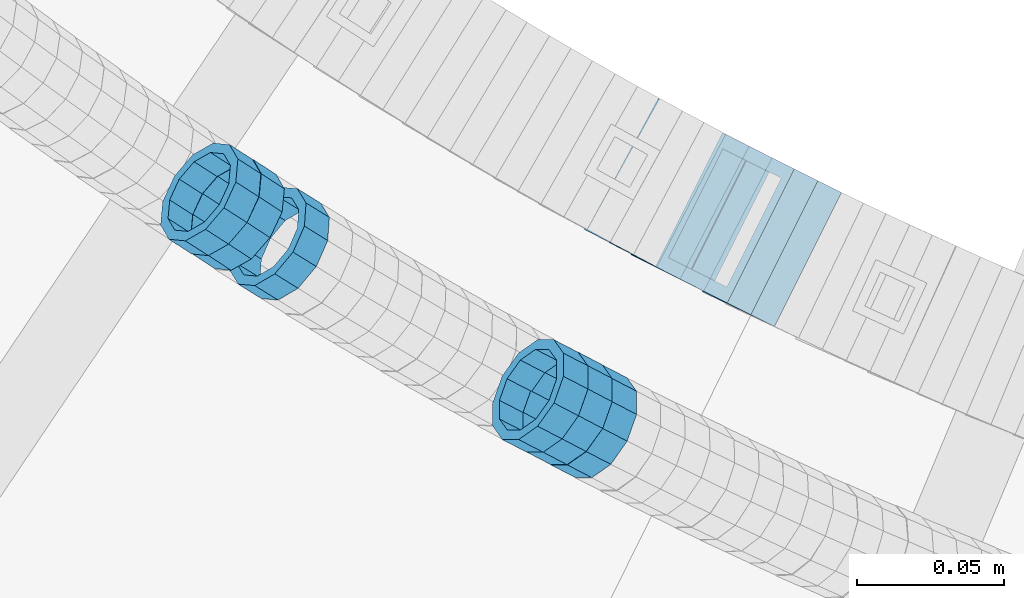
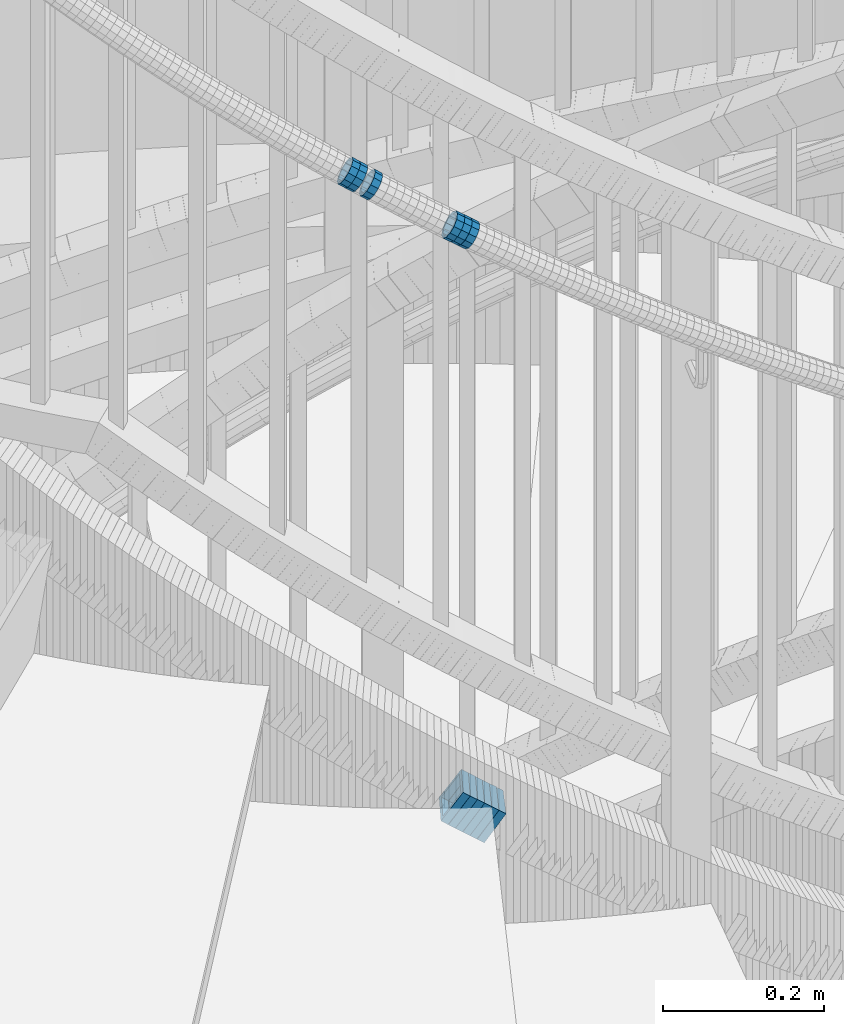
# One storey, part 694 of 975: 12 members.
"""IFC2X3 building model written with IfcOpenShell, lengths in millimetres."""

from ifc_helpers import new_model, si_unit, frame, origin_with_axes, place, context, subcontext, project, spatial, faceted_brep, material, type_object, element, save


model = new_model("IFC2X3")

# Units and contexts
model_context = context("Model", 3, precision=1e-05, world=origin_with_axes())
body_context = subcontext(model_context, "Body", "Model", "MODEL_VIEW")
ifc_project = project(units=[si_unit("LENGTHUNIT", "METRE", prefix="MILLI"), si_unit("AREAUNIT", "SQUARE_METRE"), si_unit("VOLUMEUNIT", "CUBIC_METRE"), si_unit("MASSUNIT", "GRAM", prefix="KILO"), si_unit("TIMEUNIT", "SECOND"), si_unit("PLANEANGLEUNIT", "RADIAN"), si_unit("SOLIDANGLEUNIT", "STERADIAN"), si_unit("THERMODYNAMICTEMPERATUREUNIT", "DEGREE_CELSIUS"), si_unit("LUMINOUSINTENSITYUNIT", "LUMEN")], contexts=[model_context])

# Site, building, storey
site_placement = place(None, origin_with_axes())
site = spatial("IfcSite", under=ifc_project, at=site_placement, CompositionType="ELEMENT")
building_placement = place(site_placement, origin_with_axes())
building = spatial("IfcBuilding", under=site, at=building_placement, Name="Undefined", CompositionType="ELEMENT")
storey_placement = place(building_placement, origin_with_axes())
storey = spatial("IfcBuildingStorey", under=building, at=storey_placement, Name="Undefined", CompositionType="ELEMENT", Elevation=0.0)

# Members
ifc_material = material()
member_type_1 = type_object("IfcMemberType", PredefinedType="NOTDEFINED")
member_1_placement = place(storey_placement, frame((33948.3273451, 2150.02250749635, 4718.03770832921), z_axis=(-0.527095063985726, -0.849806327066281, -2.88591763819568e-11), x_axis=(-0.720987809746689, 0.447194970842867, 0.529332821813951)))
element("IfcMember", 1, at=member_1_placement, inside=storey, type_object=member_type_1, material=ifc_material, Name="WALL", context=body_context, shape_type="Brep", body=[
    faceted_brep([(-2.1246523829177e-07, -15.367000000002, 0.0), (-1.83998054126278e-07, -13.3082123799541, 7.68350000000009), (10.9608393839299, -13.3082123799613, 7.68350000000282), (10.9608393839189, -15.3670000000093, 3.63797880709171e-12), (-1.06232619145885e-07, -7.68349999999919, 13.3082123799559), (10.9608393839408, -7.68349999999919, 13.3082123799563), (-3.63797880709171e-12, 3.63797880709171e-12, 15.3670000000002), (10.9608393839517, 3.63797880709171e-12, 15.3669999999993), (1.06225343188271e-07, 7.68350000000646, 13.3082123799559), (10.960839383959, 7.68350000000282, 13.3082123799536), (1.8399441614747e-07, 13.308212379965, 7.68350000000009), (10.9608393839553, 13.3082123799577, 7.68349999999782), (2.12461600312963e-07, 15.3670000000093, 0.0), (10.960839383959, 15.367000000002, -2.27373675443232e-12), (1.8399441614747e-07, 13.308212379965, -7.68350000000009), (10.960839383948, 13.3082123799468, -7.68350000000146), (1.06225343188271e-07, 7.68350000000646, -13.3082123799559), (10.9608393839408, 7.68349999998827, -13.3082123799563), (-3.63797880709171e-12, 3.63797880709171e-12, -15.3670000000002), (10.9608393839299, -1.09139364212751e-11, -15.3669999999993), (-1.06232619145885e-07, -7.68349999999919, -13.3082123799559), (10.9608393839226, -7.68350000001374, -13.3082123799531), (-1.83998054126278e-07, -13.3082123799541, -7.68350000000009), (10.9608393839226, -13.308212379965, -7.68349999999691), (-2.63386027654633e-07, -19.0500000000029, 0.0), (-2.28097633225843e-07, -16.4977839420972, -9.52499999999964), (10.9608393839153, -16.4977839421081, -9.52499999999645), (10.9608393839153, -19.0500000000065, 4.09272615797818e-12), (-1.31691194837913e-07, -9.52500000000146, -16.4977839420935), (10.9608393839189, -9.52500000001237, -16.4977839420908), (-3.63797880709171e-12, 3.63797880709171e-12, -19.0500000000002), (10.9608393839262, -1.45519152283669e-11, -19.0499999999984), (1.31687556859106e-07, 9.52500000000509, -16.4977839420935), (10.9608393839371, 9.5249999999869, -16.4977839420935), (2.28097633225843e-07, 16.4977839421044, -9.52499999999964), (10.9608393839553, 16.4977839420899, -9.52500000000282), (2.63382389675826e-07, 19.0500000000138, 0.0), (10.9608393839626, 19.0499999999993, -3.18323145620525e-12), (2.28097633225843e-07, 16.4977839421044, 9.52499999999964), (10.9608393839626, 16.4977839420972, 9.52499999999645), (1.31687556859106e-07, 9.52500000000509, 16.4977839420935), (10.960839383959, 9.52500000000509, 16.4977839420917), (-3.63797880709171e-12, 3.63797880709171e-12, 19.0500000000002), (10.9608393839517, 7.27595761418343e-12, 19.0499999999997), (-1.31691194837913e-07, -9.52500000000146, 16.4977839420935), (10.9608393839408, -9.52499999999782, 16.4977839420944), (-2.28097633225843e-07, -16.4977839420972, 9.52499999999964), (10.9608393839226, -16.4977839420972, 9.52500000000418)], [[[0, 1, 2, 3]], [[1, 4, 5, 2]], [[4, 6, 7, 5]], [[6, 8, 9, 7]], [[8, 10, 11, 9]], [[10, 12, 13, 11]], [[12, 14, 15, 13]], [[14, 16, 17, 15]], [[16, 18, 19, 17]], [[18, 20, 21, 19]], [[20, 22, 23, 21]], [[22, 0, 3, 23]], [[24, 25, 26, 27]], [[25, 28, 29, 26]], [[28, 30, 31, 29]], [[30, 32, 33, 31]], [[32, 34, 35, 33]], [[34, 36, 37, 35]], [[36, 38, 39, 37]], [[38, 40, 41, 39]], [[40, 42, 43, 41]], [[42, 44, 45, 43]], [[44, 46, 47, 45]], [[46, 24, 27, 47]], [[29, 31, 33, 35, 37, 39, 41, 43, 45, 47, 27, 26], [5, 7, 9, 11, 13, 15, 17, 19, 21, 23, 3, 2]], [[46, 44, 42, 40, 38, 36, 34, 32, 30, 28, 25, 24], [22, 20, 18, 16, 14, 12, 10, 8, 6, 4, 1, 0]]]),
])
member_2_placement = place(storey_placement, frame((34053.4904521803, 2090.06961976935, 4643.43531165433), z_axis=(-0.460004875804858, -0.887916389214523, -1.65827259479556e-10), x_axis=(-0.758093616720178, 0.392747294855074, 0.520618507807916)))
element("IfcMember", 2, at=member_2_placement, inside=storey, type_object=member_type_1, material=ifc_material, Name="WALL", context=body_context, shape_type="Brep", body=[
    faceted_brep([(-2.1246523829177e-07, -15.367000000002, 0.0), (-1.83998054126278e-07, -13.3082123799541, 7.68350000000009), (10.9530817580962, -13.3082123799686, 7.68350000001737), (10.9530817580853, -15.3670000000202, 2.5465851649642e-11), (-1.06232619145885e-07, -7.68349999999919, 13.3082123799559), (10.9530817581108, -7.6835000000101, 13.308212379965), (-3.63797880709171e-12, 3.63797880709171e-12, 15.3670000000002), (10.9530817581144, -3.63797880709171e-12, 15.367000000002), (1.06225343188271e-07, 7.68350000000646, 13.3082123799559), (10.9530817581326, 7.68350000000646, 13.3082123799504), (1.8399441614747e-07, 13.308212379965, 7.68350000000009), (10.9530817581362, 13.308212379965, 7.68349999999191), (2.12461600312963e-07, 15.3670000000093, 0.0), (10.9530817581399, 15.3670000000056, -1.09139364212751e-11), (1.8399441614747e-07, 13.308212379965, -7.68350000000009), (10.9530817581362, 13.3082123799613, -7.68350000000282), (1.06225343188271e-07, 7.68350000000646, -13.3082123799559), (10.9530817581217, 7.68349999999919, -13.3082123799504), (-3.63797880709171e-12, 3.63797880709171e-12, -15.3670000000002), (10.9530817581108, -7.27595761418343e-12, -15.3669999999875), (-1.06232619145885e-07, -7.68349999999919, -13.3082123799559), (10.9530817580999, -7.68350000001374, -13.3082123799359), (-1.83998054126278e-07, -13.3082123799541, -7.68350000000009), (10.9530817580926, -13.3082123799722, -7.68349999997372), (-2.63386027654633e-07, -19.0500000000029, 0.0), (-2.28097633225843e-07, -16.4977839420972, -9.52499999999964), (10.9530817580853, -16.4977839421117, -9.52499999996871), (10.953081758078, -19.0500000000211, 2.91038304567337e-11), (-1.31691194837913e-07, -9.52500000000146, -16.4977839420935), (10.9530817580926, -9.52500000001601, -16.4977839420681), (-3.63797880709171e-12, 3.63797880709171e-12, -19.0500000000002), (10.9530817581071, -7.27595761418343e-12, -19.0499999999884), (1.31687556859106e-07, 9.52500000000509, -16.4977839420935), (10.953081758129, 9.52500000000146, -16.4977839420935), (2.28097633225843e-07, 16.4977839421044, -9.52499999999964), (10.9530817581399, 16.4977839421008, -9.52500000000509), (2.63382389675826e-07, 19.0500000000138, 0.0), (10.9530817581435, 19.0500000000102, -1.09139364212751e-11), (2.28097633225843e-07, 16.4977839421044, 9.52499999999964), (10.9530817581472, 16.4977839421044, 9.5249999999869), (1.31687556859106e-07, 9.52500000000509, 16.4977839420935), (10.9530817581362, 9.52500000000509, 16.4977839420826), (-3.63797880709171e-12, 3.63797880709171e-12, 19.0500000000002), (10.9530817581217, -3.63797880709171e-12, 19.0499999999993), (-1.31691194837913e-07, -9.52500000000146, 16.4977839420935), (10.9530817581035, -9.52500000001237, 16.4977839421081), (-2.28097633225843e-07, -16.4977839420972, 9.52499999999964), (10.953081758089, -16.4977839421081, 9.52500000002328)], [[[0, 1, 2, 3]], [[1, 4, 5, 2]], [[4, 6, 7, 5]], [[6, 8, 9, 7]], [[8, 10, 11, 9]], [[10, 12, 13, 11]], [[12, 14, 15, 13]], [[14, 16, 17, 15]], [[16, 18, 19, 17]], [[18, 20, 21, 19]], [[20, 22, 23, 21]], [[22, 0, 3, 23]], [[24, 25, 26, 27]], [[25, 28, 29, 26]], [[28, 30, 31, 29]], [[30, 32, 33, 31]], [[32, 34, 35, 33]], [[34, 36, 37, 35]], [[36, 38, 39, 37]], [[38, 40, 41, 39]], [[40, 42, 43, 41]], [[42, 44, 45, 43]], [[44, 46, 47, 45]], [[46, 24, 27, 47]], [[29, 31, 33, 35, 37, 39, 41, 43, 45, 47, 27, 26], [5, 7, 9, 11, 13, 15, 17, 19, 21, 23, 3, 2]], [[46, 44, 42, 40, 38, 36, 34, 32, 30, 28, 25, 24], [22, 20, 18, 16, 14, 12, 10, 8, 6, 4, 1, 0]]]),
])
member_3_placement = place(storey_placement, frame((34045.0404337909, 2094.50392488019, 4649.25590169563), z_axis=(-0.464410514349044, -0.885620050677522, 2.87447619484737e-10), x_axis=(-0.750526887871473, 0.393568977932601, 0.530860480909108)))
element("IfcMember", 3, at=member_3_placement, inside=storey, type_object=member_type_1, material=ifc_material, Name="WALL", context=body_context, shape_type="Brep", body=[
    faceted_brep([(-2.1246523829177e-07, -15.367000000002, 0.0), (-1.83998054126278e-07, -13.3082123799541, 7.68350000000009), (10.9334349588862, -13.3082123799722, 7.68350000000555), (10.9334349588862, -15.3670000000166, 5.45696821063757e-12), (-1.06232619145885e-07, -7.68349999999919, 13.3082123799559), (10.9334349588826, -7.68350000001737, 13.3082123799609), (-3.63797880709171e-12, 3.63797880709171e-12, 15.3670000000002), (10.9334349588862, -1.45519152283669e-11, 15.3670000000043), (1.06225343188271e-07, 7.68350000000646, 13.3082123799559), (10.9334349588898, 7.68349999998827, 13.3082123799591), (1.8399441614747e-07, 13.308212379965, 7.68350000000009), (10.9334349588898, 13.3082123799395, 7.68350000000419), (2.12461600312963e-07, 15.3670000000093, 0.0), (10.9334349588971, 15.3669999999911, 3.63797880709171e-12), (1.8399441614747e-07, 13.308212379965, -7.68350000000009), (10.9334349588935, 13.3082123799431, -7.683499999996), (1.06225343188271e-07, 7.68350000000646, -13.3082123799559), (10.9334349588971, 7.68349999998827, -13.3082123799518), (-3.63797880709171e-12, 3.63797880709171e-12, -15.3670000000002), (10.9334349588971, -1.45519152283669e-11, -15.3669999999961), (-1.06232619145885e-07, -7.68349999999919, -13.3082123799559), (10.9334349588935, -7.68350000001737, -13.3082123799509), (-1.83998054126278e-07, -13.3082123799541, -7.68350000000009), (10.9334349588898, -13.3082123799686, -7.68349999999464), (-2.63386027654633e-07, -19.0500000000029, 0.0), (-2.28097633225843e-07, -16.4977839420972, -9.52499999999964), (10.9334349588898, -16.4977839421117, -9.52499999999372), (10.9334349588898, -19.0500000000211, 5.45696821063757e-12), (-1.31691194837913e-07, -9.52500000000146, -16.4977839420935), (10.9334349588971, -9.52500000001237, -16.4977839420885), (-3.63797880709171e-12, 3.63797880709171e-12, -19.0500000000002), (10.9334349588971, -1.09139364212751e-11, -19.0499999999961), (1.31687556859106e-07, 9.52500000000509, -16.4977839420935), (10.9334349589008, 9.52499999999054, -16.4977839420894), (2.28097633225843e-07, 16.4977839421044, -9.52499999999964), (10.9334349589008, 16.4977839420826, -9.52499999999645), (2.63382389675826e-07, 19.0500000000138, 0.0), (10.9334349588898, 19.0499999999884, 3.18323145620525e-12), (2.28097633225843e-07, 16.4977839421044, 9.52499999999964), (10.9334349588935, 16.497783942079, 9.52500000000282), (1.31687556859106e-07, 9.52500000000509, 16.4977839420935), (10.9334349588826, 9.52499999998327, 16.4977839420976), (-3.63797880709171e-12, 3.63797880709171e-12, 19.0500000000002), (10.9334349588826, -1.81898940354586e-11, 19.0500000000043), (-1.31691194837913e-07, -9.52500000000146, 16.4977839420935), (10.9334349588826, -9.52500000001965, 16.4977839420994), (-2.28097633225843e-07, -16.4977839420972, 9.52499999999964), (10.9334349588826, -16.4977839421117, 9.52500000000646)], [[[0, 1, 2, 3]], [[1, 4, 5, 2]], [[4, 6, 7, 5]], [[6, 8, 9, 7]], [[8, 10, 11, 9]], [[10, 12, 13, 11]], [[12, 14, 15, 13]], [[14, 16, 17, 15]], [[16, 18, 19, 17]], [[18, 20, 21, 19]], [[20, 22, 23, 21]], [[22, 0, 3, 23]], [[24, 25, 26, 27]], [[25, 28, 29, 26]], [[28, 30, 31, 29]], [[30, 32, 33, 31]], [[32, 34, 35, 33]], [[34, 36, 37, 35]], [[36, 38, 39, 37]], [[38, 40, 41, 39]], [[40, 42, 43, 41]], [[42, 44, 45, 43]], [[44, 46, 47, 45]], [[46, 24, 27, 47]], [[29, 31, 33, 35, 37, 39, 41, 43, 45, 47, 27, 26], [5, 7, 9, 11, 13, 15, 17, 19, 21, 23, 3, 2]], [[46, 44, 42, 40, 38, 36, 34, 32, 30, 28, 25, 24], [22, 20, 18, 16, 14, 12, 10, 8, 6, 4, 1, 0]]]),
])
member_4_placement = place(storey_placement, frame((34036.9904521803, 2098.66961976934, 4654.93531165437), z_axis=(-0.460004875804858, -0.887916389214523, -1.65827259479556e-10), x_axis=(-0.758093616720178, 0.392747294855074, 0.520618507807916)))
element("IfcMember", 4, at=member_4_placement, inside=storey, type_object=member_type_1, material=ifc_material, Name="WALL", context=body_context, shape_type="Brep", body=[
    faceted_brep([(-2.1246523829177e-07, -15.367000000002, 0.0), (-1.83998054126278e-07, -13.3082123799541, 7.68350000000009), (10.9530817580962, -13.3082123799686, 7.68350000001737), (10.9530817580853, -15.3670000000202, 2.5465851649642e-11), (-1.06232619145885e-07, -7.68349999999919, 13.3082123799559), (10.9530817581108, -7.6835000000101, 13.308212379965), (-3.63797880709171e-12, 3.63797880709171e-12, 15.3670000000002), (10.9530817581144, -3.63797880709171e-12, 15.367000000002), (1.06225343188271e-07, 7.68350000000646, 13.3082123799559), (10.9530817581326, 7.68350000000646, 13.3082123799504), (1.8399441614747e-07, 13.308212379965, 7.68350000000009), (10.9530817581362, 13.308212379965, 7.68349999999191), (2.12461600312963e-07, 15.3670000000093, 0.0), (10.9530817581399, 15.3670000000056, -1.09139364212751e-11), (1.8399441614747e-07, 13.308212379965, -7.68350000000009), (10.9530817581362, 13.3082123799613, -7.68350000000282), (1.06225343188271e-07, 7.68350000000646, -13.3082123799559), (10.9530817581217, 7.68349999999919, -13.3082123799504), (-3.63797880709171e-12, 3.63797880709171e-12, -15.3670000000002), (10.9530817581108, -7.27595761418343e-12, -15.3669999999875), (-1.06232619145885e-07, -7.68349999999919, -13.3082123799559), (10.9530817580999, -7.68350000001374, -13.3082123799359), (-1.83998054126278e-07, -13.3082123799541, -7.68350000000009), (10.9530817580926, -13.3082123799722, -7.68349999997372), (-2.63386027654633e-07, -19.0500000000029, 0.0), (-2.28097633225843e-07, -16.4977839420972, -9.52499999999964), (10.9530817580853, -16.4977839421117, -9.52499999996871), (10.953081758078, -19.0500000000211, 2.91038304567337e-11), (-1.31691194837913e-07, -9.52500000000146, -16.4977839420935), (10.9530817580926, -9.52500000001601, -16.4977839420681), (-3.63797880709171e-12, 3.63797880709171e-12, -19.0500000000002), (10.9530817581071, -7.27595761418343e-12, -19.0499999999884), (1.31687556859106e-07, 9.52500000000509, -16.4977839420935), (10.953081758129, 9.52500000000146, -16.4977839420935), (2.28097633225843e-07, 16.4977839421044, -9.52499999999964), (10.9530817581399, 16.4977839421008, -9.52500000000509), (2.63382389675826e-07, 19.0500000000138, 0.0), (10.9530817581435, 19.0500000000102, -1.09139364212751e-11), (2.28097633225843e-07, 16.4977839421044, 9.52499999999964), (10.9530817581472, 16.4977839421044, 9.5249999999869), (1.31687556859106e-07, 9.52500000000509, 16.4977839420935), (10.9530817581362, 9.52500000000509, 16.4977839420826), (-3.63797880709171e-12, 3.63797880709171e-12, 19.0500000000002), (10.9530817581217, -3.63797880709171e-12, 19.0499999999993), (-1.31691194837913e-07, -9.52500000000146, 16.4977839420935), (10.9530817581035, -9.52500000001237, 16.4977839421081), (-2.28097633225843e-07, -16.4977839420972, 9.52499999999964), (10.953081758089, -16.4977839421081, 9.52500000002328)], [[[0, 1, 2, 3]], [[1, 4, 5, 2]], [[4, 6, 7, 5]], [[6, 8, 9, 7]], [[8, 10, 11, 9]], [[10, 12, 13, 11]], [[12, 14, 15, 13]], [[14, 16, 17, 15]], [[16, 18, 19, 17]], [[18, 20, 21, 19]], [[20, 22, 23, 21]], [[22, 0, 3, 23]], [[24, 25, 26, 27]], [[25, 28, 29, 26]], [[28, 30, 31, 29]], [[30, 32, 33, 31]], [[32, 34, 35, 33]], [[34, 36, 37, 35]], [[36, 38, 39, 37]], [[38, 40, 41, 39]], [[40, 42, 43, 41]], [[42, 44, 45, 43]], [[44, 46, 47, 45]], [[46, 24, 27, 47]], [[29, 31, 33, 35, 37, 39, 41, 43, 45, 47, 27, 26], [5, 7, 9, 11, 13, 15, 17, 19, 21, 23, 3, 2]], [[46, 44, 42, 40, 38, 36, 34, 32, 30, 28, 25, 24], [22, 20, 18, 16, 14, 12, 10, 8, 6, 4, 1, 0]]]),
])
member_5_placement = place(storey_placement, frame((33932.8773191428, 2159.94693028384, 4729.44874619023), z_axis=(-0.547249362822599, -0.836969614078229, -1.1905467545148e-10), x_axis=(-0.714005546961997, 0.466849780975243, 0.521773284972378)))
element("IfcMember", 5, at=member_5_placement, inside=storey, type_object=member_type_1, material=ifc_material, Name="WALL", context=body_context, shape_type="Brep", body=[
    faceted_brep([(-2.1246523829177e-07, -15.367000000002, 0.0), (-1.83998054126278e-07, -13.3082123799541, 7.68350000000009), (10.9242848735521, -13.3082123800159, 7.68350000000919), (10.9242848735703, -15.3670000000457, 6.82121026329696e-12), (-1.06232619145885e-07, -7.68349999999919, 13.3082123799559), (10.9242848735521, -7.68350000005739, 13.3082123799652), (-3.63797880709171e-12, 3.63797880709171e-12, 15.3670000000002), (10.924284873563, -4.72937244921923e-11, 15.3670000000088), (1.06225343188271e-07, 7.68350000000646, 13.3082123799559), (10.9242848735885, 7.68349999997008, 13.308212379962), (1.8399441614747e-07, 13.308212379965, 7.68350000000009), (10.9242848736176, 13.3082123799468, 7.68350000000328), (2.12461600312963e-07, 15.3670000000093, 0.0), (10.9242848736394, 15.3670000000093, 0.0), (1.8399441614747e-07, 13.308212379965, -7.68350000000009), (10.9242848736576, 13.3082123799795, -7.6835000000026), (1.06225343188271e-07, 7.68350000000646, -13.3082123799559), (10.9242848736576, 7.68350000002465, -13.3082123799584), (-3.63797880709171e-12, 3.63797880709171e-12, -15.3670000000002), (10.9242848736467, 1.45519152283669e-11, -15.3670000000025), (-1.06232619145885e-07, -7.68349999999919, -13.3082123799559), (10.9242848736212, -7.68350000000282, -13.3082123799552), (-1.83998054126278e-07, -13.3082123799541, -7.68350000000009), (10.9242848735958, -13.3082123799832, -7.68349999999646), (-2.63386027654633e-07, -19.0500000000029, 0.0), (-2.28097633225843e-07, -16.4977839420972, -9.52499999999964), (10.9242848735885, -16.4977839421226, -9.52499999999577), (10.9242848735557, -19.0500000000575, 8.18545231595635e-12), (-1.31691194837913e-07, -9.52500000000146, -16.4977839420935), (10.9242848736249, -9.52500000000146, -16.4977839420942), (-3.63797880709171e-12, 3.63797880709171e-12, -19.0500000000002), (10.924284873654, 2.18278728425503e-11, -19.0500000000038), (1.31687556859106e-07, 9.52500000000509, -16.4977839420935), (10.9242848736758, 9.52500000003783, -16.4977839420985), (2.28097633225843e-07, 16.4977839421044, -9.52499999999964), (10.9242848736758, 16.4977839421299, -9.52500000000418), (2.63382389675826e-07, 19.0500000000138, 0.0), (10.9242848736503, 19.0500000000211, -1.36424205265939e-12), (2.28097633225843e-07, 16.4977839421044, 9.52499999999964), (10.9242848736249, 16.4977839420899, 9.52500000000259), (1.31687556859106e-07, 9.52500000000509, 16.4977839420935), (10.9242848735885, 9.52499999996508, 16.4977839421008), (-3.63797880709171e-12, 3.63797880709171e-12, 19.0500000000002), (10.9242848735594, -5.82076609134674e-11, 19.0500000000104), (-1.31691194837913e-07, -9.52500000000146, 16.4977839420935), (10.9242848735375, -9.52500000007058, 16.4977839421056), (-2.28097633225843e-07, -16.4977839420972, 9.52499999999964), (10.9242848735412, -16.4977839421626, 9.52500000001078)], [[[0, 1, 2, 3]], [[1, 4, 5, 2]], [[4, 6, 7, 5]], [[6, 8, 9, 7]], [[8, 10, 11, 9]], [[10, 12, 13, 11]], [[12, 14, 15, 13]], [[14, 16, 17, 15]], [[16, 18, 19, 17]], [[18, 20, 21, 19]], [[20, 22, 23, 21]], [[22, 0, 3, 23]], [[24, 25, 26, 27]], [[25, 28, 29, 26]], [[28, 30, 31, 29]], [[30, 32, 33, 31]], [[32, 34, 35, 33]], [[34, 36, 37, 35]], [[36, 38, 39, 37]], [[38, 40, 41, 39]], [[40, 42, 43, 41]], [[42, 44, 45, 43]], [[44, 46, 47, 45]], [[46, 24, 27, 47]], [[29, 31, 33, 35, 37, 39, 41, 43, 45, 47, 27, 26], [5, 7, 9, 11, 13, 15, 17, 19, 21, 23, 3, 2]], [[46, 44, 42, 40, 38, 36, 34, 32, 30, 28, 25, 24], [22, 20, 18, 16, 14, 12, 10, 8, 6, 4, 1, 0]]]),
])
member_6_placement = place(storey_placement, frame((33924.9928826893, 2164.99439859085, 4735.17471250841), z_axis=(-0.539666114785759, -0.841879138921998, -8.50668584462255e-11), x_axis=(-0.717046252832315, 0.459645033892425, 0.523995337877321)))
element("IfcMember", 6, at=member_6_placement, inside=storey, type_object=member_type_1, material=ifc_material, Name="WALL", context=body_context, shape_type="Brep", body=[
    faceted_brep([(-2.1246523829177e-07, -15.367000000002, 0.0), (-1.83998054126278e-07, -13.3082123799541, 7.68350000000009), (10.8784190028109, -13.3082123799541, 7.68349999999555), (10.8784190028309, -15.3669999999929, 2.5465851649642e-11), (-1.06232619145885e-07, -7.68349999999919, 13.3082123799559), (10.8784190027873, -7.68350000000464, 13.308212379925), (-3.63797880709171e-12, 3.63797880709171e-12, 15.3670000000002), (10.8784190027782, -9.09494701772928e-12, 15.3669999999584), (1.06225343188271e-07, 7.68350000000646, 13.3082123799559), (10.8784190027691, 7.68349999998645, 13.3082123798995), (1.8399441614747e-07, 13.308212379965, 7.68350000000009), (10.8784190027764, 13.3082123799431, 7.68349999995553), (2.12461600312963e-07, 15.3670000000093, 0.0), (10.8784190027891, 15.3669999999929, -2.91038304567337e-11), (1.8399441614747e-07, 13.308212379965, -7.68350000000009), (10.8784190028055, 13.3082123799541, -7.68350000000646), (1.06225343188271e-07, 7.68350000000646, -13.3082123799559), (10.8784190028236, 7.68350000000464, -13.3082123799431), (-3.63797880709171e-12, 3.63797880709171e-12, -15.3670000000002), (10.87841900284, 1.2732925824821e-11, -15.366999999962), (-1.06232619145885e-07, -7.68349999999919, -13.3082123799559), (10.8784190028437, -7.68349999998463, -13.308212379914), (-1.83998054126278e-07, -13.3082123799541, -7.68350000000009), (10.8784190028437, -13.3082123799413, -7.68349999996281), (-2.63386027654633e-07, -19.0500000000029, 0.0), (-2.28097633225843e-07, -16.4977839420972, -9.52499999999964), (10.8784190028491, -16.4977839420771, -9.52499999995416), (10.8784190028346, -19.0499999999902, 2.91038304567337e-11), (-1.31691194837913e-07, -9.52500000000146, -16.4977839420935), (10.8784190028582, -9.52499999998145, -16.497783942039), (-3.63797880709171e-12, 3.63797880709171e-12, -19.0500000000002), (10.8784190028473, 1.63709046319127e-11, -19.0499999999556), (1.31687556859106e-07, 9.52500000000509, -16.4977839420935), (10.8784190028291, 9.52500000000691, -16.4977839420753), (2.28097633225843e-07, 16.4977839421044, -9.52499999999964), (10.8784190028073, 16.4977839420917, -9.52500000000509), (2.63382389675826e-07, 19.0500000000138, 0.0), (10.8784190027836, 19.0499999999884, -4.00177668780088e-11), (2.28097633225843e-07, 16.4977839421044, 9.52499999999964), (10.8784190027654, 16.4977839420771, 9.52499999994325), (1.31687556859106e-07, 9.52500000000509, 16.4977839420935), (10.8784190027636, 9.52499999998327, 16.4977839420317), (-3.63797880709171e-12, 3.63797880709171e-12, 19.0500000000002), (10.8784190027709, -1.63709046319127e-11, 19.0499999999447), (-1.31691194837913e-07, -9.52500000000146, 16.4977839420935), (10.8784190027854, -9.52500000000691, 16.4977839420644), (-2.28097633225843e-07, -16.4977839420972, 9.52499999999964), (10.8784190028091, -16.4977839420899, 9.52500000000146)], [[[0, 1, 2, 3]], [[1, 4, 5, 2]], [[4, 6, 7, 5]], [[6, 8, 9, 7]], [[8, 10, 11, 9]], [[10, 12, 13, 11]], [[12, 14, 15, 13]], [[14, 16, 17, 15]], [[16, 18, 19, 17]], [[18, 20, 21, 19]], [[20, 22, 23, 21]], [[22, 0, 3, 23]], [[24, 25, 26, 27]], [[25, 28, 29, 26]], [[28, 30, 31, 29]], [[30, 32, 33, 31]], [[32, 34, 35, 33]], [[34, 36, 37, 35]], [[36, 38, 39, 37]], [[38, 40, 41, 39]], [[40, 42, 43, 41]], [[42, 44, 45, 43]], [[44, 46, 47, 45]], [[46, 24, 27, 47]], [[29, 31, 33, 35, 37, 39, 41, 43, 45, 47, 27, 26], [5, 7, 9, 11, 13, 15, 17, 19, 21, 23, 3, 2]], [[46, 44, 42, 40, 38, 36, 34, 32, 30, 28, 25, 24], [22, 20, 18, 16, 14, 12, 10, 8, 6, 4, 1, 0]]]),
])
member_type_2 = type_object("IfcMemberType", Name="HSS2X2X.188_TUBES", PredefinedType="NOTDEFINED")
member_7_placement = place(storey_placement, frame((34079.6572221313, 2169.40647430692, 3729.71953504742), z_axis=(-0.460645080913193, -0.887584423832729, 0.0), x_axis=(-0.743630284592282, 0.385934704788417, 0.545956411700677)))
element("IfcMember", 7, at=member_7_placement, inside=storey, type_object=member_type_2, material=ifc_material, Name="WALL", ObjectType="HSS2X2X.188_TUBES", context=body_context, shape_type="Brep", body=[
    faceted_brep([(0.0, 20.6374999999753, -20.6375000000298), (0.0, -20.6375000000153, -20.6375000000153), (10.6216759506497, -20.637499999968, -20.6374999999534), (10.6216759506497, 20.6375000000262, -20.6374999999643), (0.0, -20.6374999999825, 20.6375000000335), (10.6216759506169, -20.6374999999935, 20.637500000008), (0.0, 20.6375000000116, 20.6375000000189), (10.6216759506242, 20.6375000000007, 20.6374999999971), (0.0, 25.3999999999724, -25.4000000000342), (0.0, 25.400000000016, 25.4000000000196), (10.6216759506169, 25.3999999999978, 25.3999999999869), (10.6216759506533, 25.4000000000269, -25.3999999999614), (0.0, -25.399999999976, 25.4000000000378), (10.6216759506242, -25.3999999999942, 25.4000000000051), (0.0, -25.400000000016, -25.4000000000196), (10.6216759506569, -25.3999999999614, -25.3999999999432)], [[[0, 1, 2, 3]], [[1, 4, 5, 2]], [[4, 6, 7, 5]], [[6, 0, 3, 7]], [[8, 9, 10, 11]], [[9, 12, 13, 10]], [[12, 14, 15, 13]], [[14, 8, 11, 15]], [[13, 15, 11, 10], [5, 7, 3, 2]], [[14, 12, 9, 8], [6, 4, 1, 0]]]),
])
member_8_placement = place(storey_placement, frame((34087.7453193522, 2165.18185045688, 3723.84881368742), z_axis=(-0.4560907908015, -0.889933250612686, 0.0), x_axis=(-0.751579683808535, 0.385184587901855, 0.535500524863554)))
element("IfcMember", 8, at=member_8_placement, inside=storey, type_object=member_type_2, material=ifc_material, Name="WALL", ObjectType="HSS2X2X.188_TUBES", context=body_context, shape_type="Brep", body=[
    faceted_brep([(0.0, 20.6374999999753, -20.6375000000298), (0.0, -20.6375000000153, -20.6375000000153), (10.6395488625676, -20.6374999999771, -20.6374999999716), (10.6395488625531, 20.6374999999916, -20.6375000000189), (0.0, -20.6374999999825, 20.6375000000335), (10.6395488625731, -20.6374999999844, 20.6375000000153), (0.0, 20.6375000000116, 20.6375000000189), (10.6395488625585, 20.6374999999825, 20.637499999968), (0.0, 25.3999999999724, -25.4000000000342), (0.0, 25.400000000016, 25.4000000000196), (10.6395488625567, 25.3999999999778, 25.3999999999614), (10.6395488625494, 25.3999999999887, -25.4000000000233), (0.0, -25.399999999976, 25.4000000000378), (10.6395488625749, -25.3999999999851, 25.400000000016), (0.0, -25.400000000016, -25.4000000000196), (10.6395488625658, -25.399999999976, -25.3999999999687)], [[[0, 1, 2, 3]], [[1, 4, 5, 2]], [[4, 6, 7, 5]], [[6, 0, 3, 7]], [[8, 9, 10, 11]], [[9, 12, 13, 10]], [[12, 14, 15, 13]], [[14, 8, 11, 15]], [[13, 15, 11, 10], [5, 7, 3, 2]], [[14, 12, 9, 8], [6, 4, 1, 0]]]),
])
member_9_placement = place(storey_placement, frame((34095.2638117521, 2161.27270225051, 3718.18854519298), z_axis=(-0.447213595899957, -0.894427190799916, 0.0), x_axis=(-0.750454514252684, 0.375227257126342, 0.544079523183157)))
element("IfcMember", 9, at=member_9_placement, inside=storey, type_object=member_type_2, material=ifc_material, Name="WALL", ObjectType="HSS2X2X.188_TUBES", context=body_context, shape_type="Brep", body=[
    faceted_brep([(0.0, 20.6374999999753, -20.6375000000298), (0.0, -20.6375000000153, -20.6375000000153), (10.6625512894789, -20.6374999999625, -20.6374999999389), (10.6625512893879, 20.6374999999789, -20.6375000000371), (0.0, -20.6374999999825, 20.6375000000335), (10.6625512894352, -20.6374999999989, 20.6375000000153), (0.0, 20.6375000000116, 20.6375000000189), (10.6625512893443, 20.6374999999443, 20.6374999999134), (0.0, 25.3999999999724, -25.4000000000342), (0.0, 25.400000000016, 25.4000000000196), (10.6625512893297, 25.3999999999342, 25.3999999998996), (10.6625512893916, 25.399999999976, -25.4000000000415), (0.0, -25.399999999976, 25.4000000000378), (10.6625512894389, -25.399999999996, 25.400000000016), (0.0, -25.400000000016, -25.4000000000196), (10.6625512894971, -25.3999999999523, -25.3999999999214)], [[[0, 1, 2, 3]], [[1, 4, 5, 2]], [[4, 6, 7, 5]], [[6, 0, 3, 7]], [[8, 9, 10, 11]], [[9, 12, 13, 10]], [[12, 14, 15, 13]], [[14, 8, 11, 15]], [[13, 15, 11, 10], [5, 7, 3, 2]], [[14, 12, 9, 8], [6, 4, 1, 0]]]),
])
member_10_placement = place(storey_placement, frame((34103.4149912991, 2157.19711247702, 3712.3798872962), z_axis=(-0.447213595899957, -0.894427190799916, 0.0), x_axis=(-0.754280757630278, 0.377140378815139, 0.537425039736583)))
element("IfcMember", 10, at=member_10_placement, inside=storey, type_object=member_type_2, material=ifc_material, Name="WALL", ObjectType="HSS2X2X.188_TUBES", context=body_context, shape_type="Brep", body=[
    faceted_brep([(0.0, 20.6374999999753, -20.6375000000298), (0.0, -20.6375000000153, -20.6375000000153), (10.6061303028146, -20.6374999999571, -20.6374999999643), (10.6061303027491, 20.6374999999971, -20.6375000000007), (0.0, -20.6374999999825, 20.6375000000335), (10.6061303027855, -20.6374999999825, 20.6375000000116), (0.0, 20.6375000000116, 20.6375000000189), (10.6061303027236, 20.637499999968, 20.6374999999716), (0.0, 25.3999999999724, -25.4000000000342), (0.0, 25.400000000016, 25.4000000000196), (10.6061303027163, 25.3999999999651, 25.3999999999651), (10.6061303027454, 25.3999999999942, -25.4000000000051), (0.0, -25.399999999976, 25.4000000000378), (10.6061303027891, -25.3999999999796, 25.4000000000124), (0.0, -25.400000000016, -25.4000000000196), (10.6061303028182, -25.3999999999505, -25.3999999999542)], [[[0, 1, 2, 3]], [[1, 4, 5, 2]], [[4, 6, 7, 5]], [[6, 0, 3, 7]], [[8, 9, 10, 11]], [[9, 12, 13, 10]], [[12, 14, 15, 13]], [[14, 8, 11, 15]], [[13, 15, 11, 10], [5, 7, 3, 2]], [[14, 12, 9, 8], [6, 4, 1, 0]]]),
])
member_11_placement = place(storey_placement, frame((34111.2638117521, 2153.27270225051, 3706.68854519298), z_axis=(-0.447213595899957, -0.894427190799916, 0.0), x_axis=(-0.750454514252684, 0.375227257126342, 0.544079523183157)))
element("IfcMember", 11, at=member_11_placement, inside=storey, type_object=member_type_2, material=ifc_material, Name="WALL", ObjectType="HSS2X2X.188_TUBES", context=body_context, shape_type="Brep", body=[
    faceted_brep([(0.0, 20.6374999999753, -20.6375000000298), (0.0, -20.6375000000153, -20.6375000000153), (10.6625512894789, -20.6374999999625, -20.6374999999389), (10.6625512893879, 20.6374999999789, -20.6375000000371), (0.0, -20.6374999999825, 20.6375000000335), (10.6625512894352, -20.6374999999989, 20.6375000000153), (0.0, 20.6375000000116, 20.6375000000189), (10.6625512893443, 20.6374999999443, 20.6374999999134), (0.0, 25.3999999999724, -25.4000000000342), (0.0, 25.400000000016, 25.4000000000196), (10.6625512893297, 25.3999999999342, 25.3999999998996), (10.6625512893916, 25.399999999976, -25.4000000000415), (0.0, -25.399999999976, 25.4000000000378), (10.6625512894389, -25.399999999996, 25.400000000016), (0.0, -25.400000000016, -25.4000000000196), (10.6625512894971, -25.3999999999523, -25.3999999999214)], [[[0, 1, 2, 3]], [[1, 4, 5, 2]], [[4, 6, 7, 5]], [[6, 0, 3, 7]], [[8, 9, 10, 11]], [[9, 12, 13, 10]], [[12, 14, 15, 13]], [[14, 8, 11, 15]], [[13, 15, 11, 10], [5, 7, 3, 2]], [[14, 12, 9, 8], [6, 4, 1, 0]]]),
])
member_12_placement = place(storey_placement, frame((34119.1295213073, 2149.25974741734, 3700.84843311805), z_axis=(-0.433815618951114, -0.901001669673293, 6.19365891907365e-11), x_axis=(-0.760940849966125, 0.366378927983682, 0.535476893976163)))
element("IfcMember", 12, at=member_12_placement, inside=storey, type_object=member_type_2, material=ifc_material, Name="WALL", ObjectType="HSS2X2X.188_TUBES", context=body_context, shape_type="Brep", body=[
    faceted_brep([(0.0, 20.6374999999753, -20.6375000000298), (0.0, -20.6375000000153, -20.6375000000153), (10.6395488625676, -20.6374999999771, -20.6374999999716), (10.6395488625531, 20.6374999999916, -20.6375000000189), (0.0, -20.6374999999825, 20.6375000000335), (10.6395488625731, -20.6374999999844, 20.6375000000153), (0.0, 20.6375000000116, 20.6375000000189), (10.6395488625585, 20.6374999999825, 20.637499999968), (0.0, 25.3999999999724, -25.4000000000342), (0.0, 25.400000000016, 25.4000000000196), (10.6395488625567, 25.3999999999778, 25.3999999999614), (10.6395488625494, 25.3999999999887, -25.4000000000233), (0.0, -25.399999999976, 25.4000000000378), (10.6395488625749, -25.3999999999851, 25.400000000016), (0.0, -25.400000000016, -25.4000000000196), (10.6395488625658, -25.399999999976, -25.3999999999687)], [[[0, 1, 2, 3]], [[1, 4, 5, 2]], [[4, 6, 7, 5]], [[6, 0, 3, 7]], [[8, 9, 10, 11]], [[9, 12, 13, 10]], [[12, 14, 15, 13]], [[14, 8, 11, 15]], [[13, 15, 11, 10], [5, 7, 3, 2]], [[14, 12, 9, 8], [6, 4, 1, 0]]]),
])

save(model, "model.ifc")
